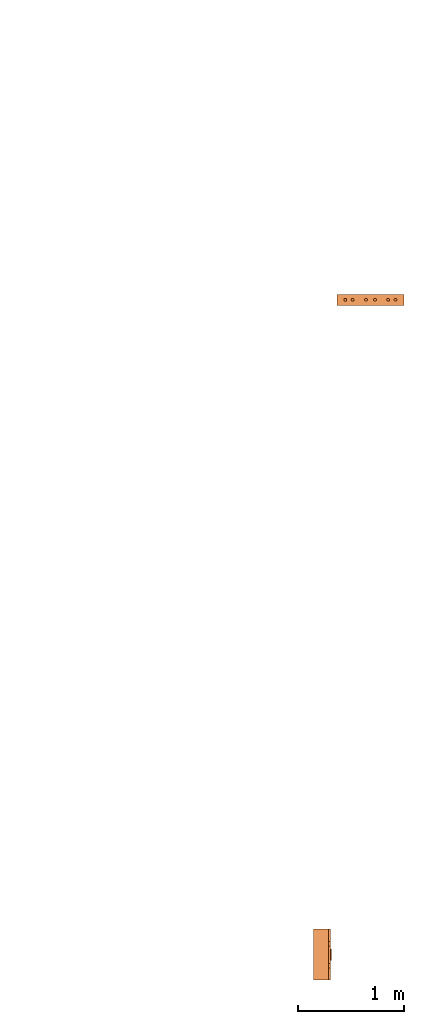
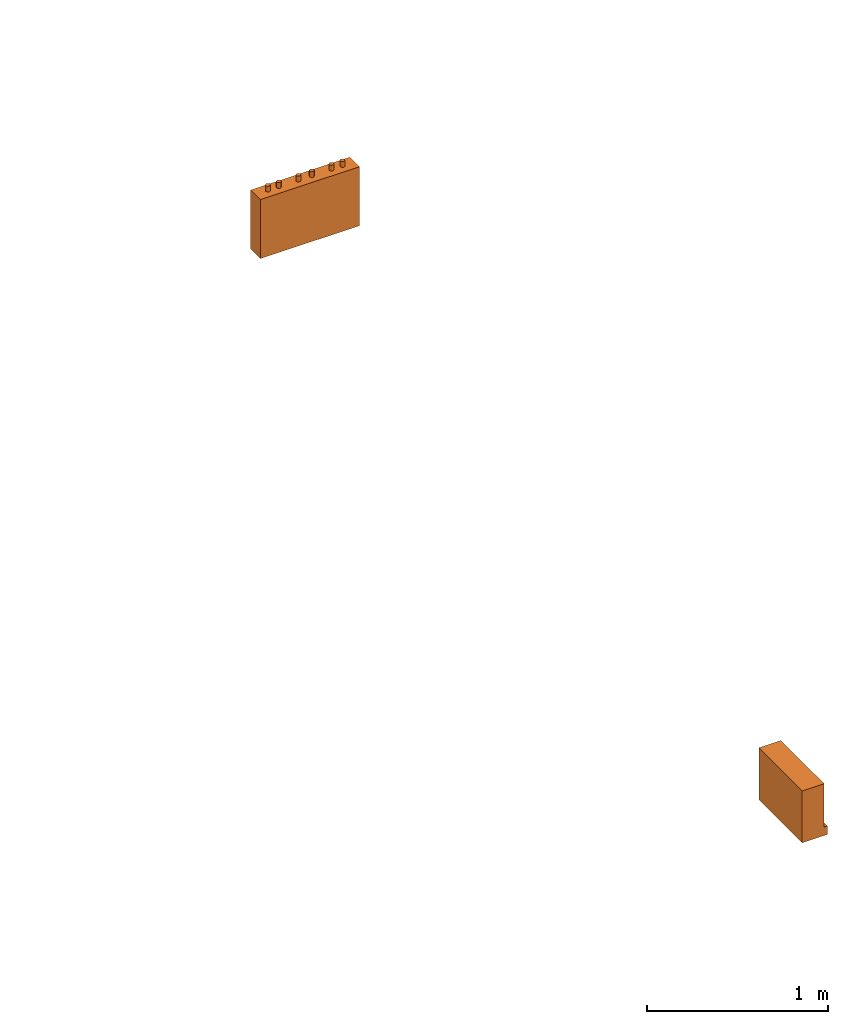
# One storey, part 2 of 3: 2 proxies.
"""IFC2X3 building model written with IfcOpenShell, lengths in millimetres."""

import ifcopenshell
import ifcopenshell.guid

model = None  # the IFC model being written
_history = None  # IfcOwnerHistory: only IFC2X3 demands one
_inside = {}  # id of a spatial element -> (the spatial element, [elements in it])
_under = {}  # id of a project, library or spatial element -> (it, [spatial elements below it])
_declared = {}  # id of a project -> (the project, [libraries it declares])
_typed = {}  # id of a type object -> (the type object, [elements of that type])
_made_of = {}  # id of a material, layer set ... -> (it, [elements and type objects made of it])


def new_model(schema):
    """Start an empty IFC model of exactly this schema.

    Asked for "IFC4X3", IfcOpenShell would pick the latest addendum, in which some entities
    have other attributes; the version numbers below select the first issue.
    IFC2X3 requires an IfcOwnerHistory on every rooted entity: one is made here for all.
    """
    global model, _history
    if schema == "IFC4X3":
        model = ifcopenshell.file(schema_version=(4, 3, 0, 0))
    else:
        model = ifcopenshell.file(schema=schema)
    _inside.clear()
    _under.clear()
    _declared.clear()
    _typed.clear()
    _made_of.clear()
    _history = None
    if model.schema == "IFC2X3":
        org = make("IfcOrganization", Name="unknown")
        user = make(
            "IfcPersonAndOrganization",
            ThePerson=make("IfcPerson", FamilyName="unknown"),
            TheOrganization=org,
        )
        app = make(
            "IfcApplication",
            ApplicationDeveloper=org,
            Version="unknown",
            ApplicationFullName="unknown",
            ApplicationIdentifier="unknown",
        )
        _history = make(
            "IfcOwnerHistory",
            OwningUser=user,
            OwningApplication=app,
            ChangeAction="ADDED",
            CreationDate=0,
        )
    return model


def make(cls, **values):
    """One entity of the class cls with the attributes given. An attribute that is None is left unset."""
    return model.create_entity(
        cls, **{name: value for name, value in values.items() if value is not None}
    )


def entity(cls, *values):
    """Any entity or typed value of the class cls, its attributes in the order of the schema. None: left unset."""
    e = model.create_entity(cls)
    for i, value in enumerate(values):
        if value is not None:
            e[i] = value
    return e


def rooted(cls, **values):
    """An entity with a GlobalId (a new one), such as an element, a storey or a relation."""
    return make(cls, GlobalId=ifcopenshell.guid.new(), OwnerHistory=_history, **values)


def si_unit(unit_type, name, prefix=None):
    """IfcSIUnit, for example si_unit("LENGTHUNIT", "METRE", prefix="MILLI")."""
    return make("IfcSIUnit", UnitType=unit_type, Prefix=prefix, Name=name)


def converted_unit(unit_type, name, factor, base, dimensions=None, offset=None):
    """IfcConversionBasedUnit, such as the inch: factor (a typed value) times the base unit."""
    return make(
        "IfcConversionBasedUnit"
        if offset is None
        else "IfcConversionBasedUnitWithOffset",
        ConversionOffset=offset,
        Dimensions=None
        if dimensions is None
        else entity("IfcDimensionalExponents", *dimensions),
        UnitType=unit_type,
        Name=name,
        ConversionFactor=make(
            "IfcMeasureWithUnit", ValueComponent=factor, UnitComponent=base
        ),
    )


def derived_unit(unit_type, elements):
    """IfcDerivedUnit: a product of units, each with its exponent."""
    return make(
        "IfcDerivedUnit",
        Elements=[
            make("IfcDerivedUnitElement", Unit=unit, Exponent=power)
            for unit, power in elements
        ],
        UnitType=unit_type,
    )


def assignment(units):
    """IfcUnitAssignment: the units of a project."""
    return None if units is None else make("IfcUnitAssignment", Units=units)


def point(xyz):
    """IfcCartesianPoint."""
    return None if xyz is None else make("IfcCartesianPoint", Coordinates=xyz)


def direction(xyz):
    """IfcDirection."""
    return None if xyz is None else make("IfcDirection", DirectionRatios=xyz)


def frame(location, z_axis=None, x_axis=None):
    """IfcAxis2Placement3D, a coordinate frame: its origin and axes. An axis left out is left unset."""
    return make(
        "IfcAxis2Placement3D",
        Location=point(location),
        Axis=direction(z_axis),
        RefDirection=direction(x_axis),
    )


def origin():
    """The frame at (0, 0, 0) with its axes left unset."""
    return frame((0.0, 0.0, 0.0))


def place(relative_to, where):
    """IfcLocalPlacement: puts the frame where relative to a parent placement (None: the world)."""
    return make(
        "IfcLocalPlacement", PlacementRelTo=relative_to, RelativePlacement=where
    )


def context(
    kind, dimensions, precision=None, world=None, true_north=None, identifier=None
):
    """IfcGeometricRepresentationContext, for example the 3D "Model" context."""
    return make(
        "IfcGeometricRepresentationContext",
        ContextIdentifier=identifier,
        ContextType=kind,
        CoordinateSpaceDimension=dimensions,
        Precision=precision,
        WorldCoordinateSystem=world,
        TrueNorth=true_north,
    )


def subcontext(parent, identifier, kind, view, scale=None):
    """IfcGeometricRepresentationSubContext, for example "Body" below "Model"."""
    return make(
        "IfcGeometricRepresentationSubContext",
        ContextIdentifier=identifier,
        ContextType=kind,
        ParentContext=parent,
        TargetScale=scale,
        TargetView=view,
    )


def project(units=None, contexts=None):
    """IfcProject with its units and contexts."""
    return rooted(
        "IfcProject",
        Name="project",
        RepresentationContexts=contexts,
        UnitsInContext=assignment(units),
    )


def spatial(cls, under=None, at=None, **own):
    """A site, building, storey or space (cls), placed at a placement, below another one or the project."""
    s = rooted(cls, ObjectPlacement=at, **own)
    if under is not None:
        _under.setdefault(under.id(), (under, []))[1].append(s)
    return s


def faces_of(points, faces, orient=None, outer=None):
    """IfcFace entities. A face is a list of loops; a loop is a list of indices into points, from 0.

    orient and outer hold one flag for each loop. By default every Orientation is true, the
    first loop of a face is its IfcFaceOuterBound and the others are IfcFaceBound.
    """
    made = []
    for i, loops in enumerate(faces):
        bounds = []
        for j, loop in enumerate(loops):
            is_outer = j == 0 if outer is None else outer[i][j]
            bounds.append(
                make(
                    "IfcFaceOuterBound" if is_outer else "IfcFaceBound",
                    Bound=make("IfcPolyLoop", Polygon=[points[k] for k in loop]),
                    Orientation=True if orient is None else orient[i][j],
                )
            )
        made.append(make("IfcFace", Bounds=bounds))
    return made


def faceted_brep(points, faces, orient=None, outer=None, voids=None):
    """IfcFacetedBrep: a solid bounded by flat faces; with voids (closed shells), ...WithVoids."""
    shared = [point(p) for p in points]
    hull = make("IfcClosedShell", CfsFaces=faces_of(shared, faces, orient, outer))
    if voids is None:
        return make("IfcFacetedBrep", Outer=hull)
    return make(
        "IfcFacetedBrepWithVoids",
        Outer=hull,
        Voids=[
            make(cls, CfsFaces=faces_of(shared, fs, o, b)) for cls, fs, o, b in voids
        ],
    )


def shape(context_of_items, identifier, shape_type, items):
    """IfcShapeRepresentation: the items that make up one representation, for example the "Body"."""
    return make(
        "IfcShapeRepresentation",
        ContextOfItems=context_of_items,
        RepresentationIdentifier=identifier,
        RepresentationType=shape_type,
        Items=items,
    )


def source(mapping_origin, context_of_items, identifier, shape_type, items):
    """IfcRepresentationMap: a shape defined once, which mapped items show again and again."""
    return make(
        "IfcRepresentationMap",
        MappingOrigin=mapping_origin,
        MappedRepresentation=shape(context_of_items, identifier, shape_type, items),
    )


def transform(
    local_origin,
    x_axis=None,
    y_axis=None,
    z_axis=None,
    scale=None,
    scale2=None,
    scale3=None,
    uniform=True,
):
    """IfcCartesianTransformationOperator3D, or its non-uniform kind. x_axis, y_axis, z_axis: its Axis1, 2, 3."""
    if uniform:
        return make(
            "IfcCartesianTransformationOperator3D",
            Axis1=direction(x_axis),
            Axis2=direction(y_axis),
            LocalOrigin=point(local_origin),
            Scale=scale,
            Axis3=direction(z_axis),
        )
    return make(
        "IfcCartesianTransformationOperator3DnonUniform",
        Axis1=direction(x_axis),
        Axis2=direction(y_axis),
        LocalOrigin=point(local_origin),
        Scale=scale,
        Axis3=direction(z_axis),
        Scale2=scale2,
        Scale3=scale3,
    )


def mapped(mapping_source, mapping_target):
    """IfcMappedItem: shows the shape of a source again, moved by a transform."""
    return make(
        "IfcMappedItem", MappingSource=mapping_source, MappingTarget=mapping_target
    )


def material(Name=None, Category=None):
    """IfcMaterial."""
    return make("IfcMaterial", Name=Name, Category=Category)


def material_list(materials):
    """IfcMaterialList."""
    return make("IfcMaterialList", Materials=materials)


def made_of(thing, what):
    """Note that an element or type object is made of a material, layer set ...; save() writes the relation."""
    if what is not None:
        _made_of.setdefault(what.id(), (what, []))[1].append(thing)
    return thing


def type_object(cls, material=None, **own):
    """A type object (cls), such as IfcWallType, which elements share."""
    return made_of(rooted(cls, **own), material)


def type_shapes(of_type, sources):
    """Give a type object the sources (RepresentationMaps) that its elements show as mapped items."""
    of_type.RepresentationMaps = sources


def element(
    cls,
    number,
    at=None,
    inside=None,
    cuts=None,
    type_object=None,
    material=None,
    context=None,
    identifier="Body",
    shape_type=None,
    held_by="IfcProductDefinitionShape",
    body=None,
    shapes=None,
    **own,
):
    """One element of the class cls, such as IfcWall. Its Tag is "e" and its number.

    at: its placement. inside: the storey or other place that contains it. cuts: it is an
    opening in that element (IfcRelVoidsElement). A single representation is given by context,
    identifier, shape_type and body (its items); several are given by shapes. held_by: the class
    of the entity that holds the representations. save() writes the other relations.
    """
    e = rooted(cls, Tag="e%d" % number, ObjectPlacement=at, **own)
    if body is not None:
        shapes = [shape(context, identifier, shape_type, body)]
    if shapes is not None:
        e.Representation = make(held_by, Representations=shapes)
    if inside is not None:
        _inside.setdefault(inside.id(), (inside, []))[1].append(e)
    if cuts is not None:
        rooted(
            "IfcRelVoidsElement", RelatingBuildingElement=cuts, RelatedOpeningElement=e
        )
    if type_object is not None:
        _typed.setdefault(type_object.id(), (type_object, []))[1].append(e)
    return made_of(e, material)


def aggregate(whole, parts):
    """IfcRelAggregates: a whole, such as a stair, and the parts it consists of."""
    return rooted("IfcRelAggregates", RelatingObject=whole, RelatedObjects=parts)


def save(model, path):
    """Write the relations noted so far, then the file.

    IfcRelAggregates (storeys below a building ...), IfcRelContainedInSpatialStructure (elements
    in a storey), IfcRelDefinesByType, IfcRelAssociatesMaterial and IfcRelDeclares: one each for
    every whole, place, type object, material and project.
    """
    for whole, parts in _under.values():
        aggregate(whole, parts)
    for where, things in _inside.values():
        rooted(
            "IfcRelContainedInSpatialStructure",
            RelatedElements=things,
            RelatingStructure=where,
        )
    for kind, things in _typed.values():
        rooted("IfcRelDefinesByType", RelatedObjects=things, RelatingType=kind)
    for what, things in _made_of.values():
        rooted("IfcRelAssociatesMaterial", RelatedObjects=things, RelatingMaterial=what)
    for by, libraries in _declared.values():
        rooted("IfcRelDeclares", RelatingContext=by, RelatedDefinitions=libraries)
    model.write(path)


model = new_model("IFC2X3")

# Units and contexts
model_context = context("Model", 3, precision=0.01, world=origin(), true_north=direction((6.12303176911189e-17, 1.0)))
body_context = subcontext(model_context, "Body", "Model", "MODEL_VIEW")
ifc_project = project(units=[si_unit("LENGTHUNIT", "METRE", prefix="MILLI"), si_unit("AREAUNIT", "SQUARE_METRE"), si_unit("VOLUMEUNIT", "CUBIC_METRE"), converted_unit("PLANEANGLEUNIT", "DEGREE", entity("IfcRatioMeasure", 0.0174532925199433), si_unit("PLANEANGLEUNIT", "RADIAN"), dimensions=[0, 0, 0, 0, 0, 0, 0]), si_unit("MASSUNIT", "GRAM", prefix="KILO"), derived_unit("MASSDENSITYUNIT", [(si_unit("MASSUNIT", "GRAM", prefix="KILO"), 1), (si_unit("LENGTHUNIT", "METRE"), -3)]), derived_unit("MOMENTOFINERTIAUNIT", [(si_unit("LENGTHUNIT", "METRE"), 4)]), si_unit("TIMEUNIT", "SECOND"), si_unit("FREQUENCYUNIT", "HERTZ"), si_unit("THERMODYNAMICTEMPERATUREUNIT", "DEGREE_CELSIUS"), derived_unit("THERMALTRANSMITTANCEUNIT", [(si_unit("MASSUNIT", "GRAM", prefix="KILO"), 1), (si_unit("THERMODYNAMICTEMPERATUREUNIT", "KELVIN"), -1), (si_unit("TIMEUNIT", "SECOND"), -3)]), derived_unit("VOLUMETRICFLOWRATEUNIT", [(si_unit("LENGTHUNIT", "METRE"), 3), (si_unit("TIMEUNIT", "SECOND"), -1)]), derived_unit("MASSFLOWRATEUNIT", [(si_unit("MASSUNIT", "GRAM", prefix="KILO"), 1), (si_unit("TIMEUNIT", "SECOND"), -1)]), derived_unit("ROTATIONALFREQUENCYUNIT", [(si_unit("TIMEUNIT", "SECOND"), -1)]), si_unit("ELECTRICCURRENTUNIT", "AMPERE"), si_unit("ELECTRICVOLTAGEUNIT", "VOLT"), si_unit("POWERUNIT", "WATT"), si_unit("FORCEUNIT", "NEWTON", prefix="KILO"), si_unit("ILLUMINANCEUNIT", "LUX"), si_unit("LUMINOUSFLUXUNIT", "LUMEN"), si_unit("LUMINOUSINTENSITYUNIT", "CANDELA"), derived_unit("USERDEFINED", [(si_unit("MASSUNIT", "GRAM", prefix="KILO"), -1), (si_unit("LENGTHUNIT", "METRE"), -2), (si_unit("TIMEUNIT", "SECOND"), 3), (si_unit("LUMINOUSFLUXUNIT", "LUMEN"), 1)]), derived_unit("LINEARVELOCITYUNIT", [(si_unit("LENGTHUNIT", "METRE"), 1), (si_unit("TIMEUNIT", "SECOND"), -1)]), si_unit("PRESSUREUNIT", "PASCAL"), derived_unit("USERDEFINED", [(si_unit("LENGTHUNIT", "METRE"), -2), (si_unit("MASSUNIT", "GRAM", prefix="KILO"), 1), (si_unit("TIMEUNIT", "SECOND"), -2)]), derived_unit("LINEARFORCEUNIT", [(si_unit("MASSUNIT", "GRAM", prefix="KILO"), 1), (si_unit("LENGTHUNIT", "METRE"), 1), (si_unit("TIMEUNIT", "SECOND"), -2), (si_unit("LENGTHUNIT", "METRE"), -1)]), derived_unit("PLANARFORCEUNIT", [(si_unit("MASSUNIT", "GRAM", prefix="KILO"), 1), (si_unit("LENGTHUNIT", "METRE"), 1), (si_unit("TIMEUNIT", "SECOND"), -2), (si_unit("LENGTHUNIT", "METRE"), -2)])], contexts=[model_context])

# Site, building, storey
site_placement = place(None, frame((0.0, 2493.83037508239, 0.0)))
site = spatial("IfcSite", under=ifc_project, at=site_placement, CompositionType="ELEMENT")
building_placement = place(site_placement, origin())
building = spatial("IfcBuilding", under=site, at=building_placement, CompositionType="ELEMENT")
storey_placement = place(building_placement, frame((0.0, 0.0, 12000.0)))
storey = spatial("IfcBuildingStorey", under=building, at=storey_placement, Name="04", CompositionType="ELEMENT", Elevation=12000.0)

# Proxies
ifc_material_1 = material()
ifc_material_2 = material()
ifc_material_list_1 = material_list([ifc_material_1, ifc_material_2])
building_element_proxy_type_1 = type_object("IfcBuildingElementProxyType", PredefinedType="NOTDEFINED", material=ifc_material_1)
shared_shape_1 = source(origin(), body_context, "Body", "Brep", [
    faceted_brep([(168.201612490282, 212.500000000001, 135.54049916809), (168.201612490282, 201.109127034741, 126.799974925206), (168.201612490282, 192.368602791857, 115.409101959946), (168.201612490282, 186.874079554102, 102.144149440585), (168.201612490282, 185.0, 87.9091019599461), (168.201612490282, 186.874079554102, 73.6740544793074), (168.201612490282, 192.368602791856, 60.4091019599461), (168.201612490282, 201.10912703474, 49.0182289946861), (168.201612490282, 212.500000000001, 40.2777047518019), (168.201612490282, 225.764952519362, 34.7831815140474), (168.201612490282, 240.0, 32.9091019599461), (168.201612490282, 254.235047480639, 34.7831815140472), (168.201612490282, 267.5, 40.2777047518019), (168.201612490282, 278.890872965261, 49.0182289946858), (168.201612490282, 287.631397208145, 60.4091019599458), (168.201612490282, 293.125920445899, 73.6740544793071), (168.201612490282, 295.0, 87.9091019599458), (168.201612490282, 293.125920445899, 102.144149440584), (168.201612490282, 287.631397208145, 115.409101959946), (168.201612490282, 278.890872965261, 126.799974925206), (168.201612490282, 267.500000000001, 135.54049916809), (168.201612490282, 254.235047480639, 141.035022405845), (168.201612490282, 240.0, 142.909101959946), (168.201612490282, 225.764952519362, 141.035022405845), (160.0, 225.764952519362, 34.7831815140474), (160.0, 212.500000000001, 40.2777047518019), (160.0, 201.10912703474, 49.0182289946861), (160.0, 192.368602791856, 60.4091019599461), (160.0, 186.874079554102, 73.6740544793074), (160.0, 185.0, 87.9091019599463), (160.0, 186.874079554102, 102.144149440585), (160.0, 192.368602791857, 115.409101959946), (160.0, 201.109127034741, 126.799974925206), (160.0, 212.500000000001, 135.54049916809), (160.0, 225.764952519362, 141.035022405845), (160.0, 240.0, 142.909101959946), (160.0, 254.235047480639, 141.035022405845), (160.0, 267.500000000001, 135.54049916809), (160.0, 278.890872965261, 126.799974925206), (160.0, 287.631397208145, 115.409101959946), (160.0, 293.125920445899, 102.144149440584), (160.0, 295.0, 87.9091019599458), (160.0, 293.125920445899, 73.6740544793071), (160.0, 287.631397208145, 60.4091019599458), (160.0, 278.890872965261, 49.0182289946858), (160.0, 267.5, 40.2777047518019), (160.0, 254.235047480639, 34.7831815140472), (160.0, 240.0, 32.9091019599461)], [[[0, 1, 2, 3, 4, 5, 6, 7, 8, 9, 10, 11, 12, 13, 14, 15, 16, 17, 18, 19, 20, 21, 22, 23]], [[24, 25, 26, 27, 28, 29, 30, 31, 32, 33, 34, 35, 36, 37, 38, 39, 40, 41, 42, 43, 44, 45, 46, 47]], [[40, 17, 16, 41]], [[39, 18, 17, 40]], [[20, 19, 38, 37]], [[39, 38, 19, 18]], [[21, 20, 37, 36]], [[22, 21, 36, 35]], [[34, 23, 22, 35]], [[33, 0, 23, 34]], [[2, 1, 32, 31]], [[33, 32, 1, 0]], [[3, 2, 31, 30]], [[4, 3, 30, 29]], [[28, 5, 4, 29]], [[27, 6, 5, 28]], [[8, 7, 26, 25]], [[27, 26, 7, 6]], [[9, 8, 25, 24]], [[10, 9, 24, 47]], [[46, 11, 10, 47]], [[45, 12, 11, 46]], [[14, 13, 44, 43]], [[45, 44, 13, 12]], [[15, 14, 43, 42]], [[16, 15, 42, 41]]]),
    faceted_brep([(160.0, 0.0, 0.0), (160.0, 480.0, 0.0), (160.0, 480.0, 58.2870579365997), (160.0, 365.0, 58.2870579366005), (160.0, 322.247482084292, 175.748635534839), (160.0, 157.75251791571, 175.748635534839), (160.0, 115.0, 58.2870579366), (160.0, 0.0, 58.2870579365997), (0.0, 480.0, 0.0), (0.0, 0.0, 0.0), (0.0, 0.0, 350.0), (0.0, 480.0, 350.0), (140.211167148102, 480.0, 350.0), (140.211167148102, 480.0, 58.2870579365997), (140.211167148102, 0.0, 350.0), (140.211167148102, 0.0, 58.2870579365997), (140.211167148102, 365.0, 58.2870579366), (140.211167148102, 115.0, 58.2870579366), (140.211167148102, 157.75251791571, 175.748635534839), (140.211167148102, 322.247482084292, 175.748635534839)], [[[0, 1, 2, 3, 4, 5, 6, 7]], [[8, 9, 10, 11]], [[8, 11, 12, 13, 2, 1]], [[11, 10, 14, 12]], [[10, 9, 0, 7, 15, 14]], [[1, 0, 9, 8]], [[16, 13, 12, 14, 15, 17, 18, 19]], [[13, 16, 3, 2]], [[17, 15, 7, 6]], [[18, 17, 6, 5]], [[19, 18, 5, 4]], [[16, 19, 4, 3]]]),
])
type_shapes(building_element_proxy_type_1, [shared_shape_1])
proxy_1_placement = place(storey_placement, frame((62632.608534949, -553.831148726475, 1500.0)))
element("IfcBuildingElementProxy", 1, at=proxy_1_placement, inside=storey, type_object=building_element_proxy_type_1, material=ifc_material_list_1, context=body_context, shape_type="MappedRepresentation", body=[
    mapped(shared_shape_1, transform((0.0, 0.0, 0.0), scale=1.0)),
])
ifc_material_3 = material()
ifc_material_list_2 = material_list([ifc_material_3, ifc_material_2])
building_element_proxy_type_2 = type_object("IfcBuildingElementProxyType", PredefinedType="NOTDEFINED", material=ifc_material_3)
shared_shape_2 = source(origin(), body_context, "Body", "Brep", [
    faceted_brep([(61.7366777047886, 89.258069163288, 398.0), (63.9615384211591, 86.3585742266764, 398.0), (65.3601443362239, 82.9820408581116, 398.0), (65.837182768177, 79.3585742266763, 398.0), (65.3601443362239, 75.735107595241, 398.0), (63.9615384211591, 72.3585742266763, 398.0), (61.7366777047886, 69.4590792900646, 398.0), (58.8371827681769, 67.2342185736942, 398.0), (55.4606493996122, 65.8356126586294, 398.0), (51.8371827681769, 65.3585742266764, 398.0), (48.2137161367416, 65.8356126586295, 398.0), (44.8371827681769, 67.2342185736943, 398.0), (41.9376878315653, 69.4590792900647, 398.0), (39.7128271151948, 72.3585742266764, 398.0), (38.31422120013, 75.7351075952411, 398.0), (37.837182768177, 79.3585742266764, 398.0), (38.31422120013, 82.9820408581117, 398.0), (39.7128271151949, 86.3585742266764, 398.0), (41.9376878315653, 89.258069163288, 398.0), (44.837182768177, 91.4829298796585, 398.0), (48.2137161367417, 92.8815357947233, 398.0), (51.837182768177, 93.3585742266764, 398.0), (55.4606493996123, 92.8815357947233, 398.0), (58.837182768177, 91.4829298796585, 398.0), (58.8371827681769, 67.2342185736942, 436.716690815491), (61.7366777047886, 69.4590792900646, 436.716690815491), (63.9615384211591, 72.3585742266763, 436.716690815491), (65.3601443362239, 75.735107595241, 436.716690815491), (65.837182768177, 79.3585742266764, 436.716690815491), (65.3601443362239, 82.9820408581116, 436.716690815491), (63.9615384211591, 86.3585742266764, 436.716690815491), (61.7366777047886, 89.258069163288, 436.716690815491), (58.837182768177, 91.4829298796585, 436.716690815491), (55.4606493996123, 92.8815357947233, 436.716690815491), (51.837182768177, 93.3585742266764, 436.716690815491), (48.2137161367417, 92.8815357947233, 436.716690815491), (44.837182768177, 91.4829298796585, 436.716690815491), (41.9376878315653, 89.258069163288, 436.716690815491), (39.7128271151949, 86.3585742266764, 436.716690815491), (38.31422120013, 82.9820408581117, 436.716690815491), (37.837182768177, 79.3585742266764, 436.716690815491), (38.31422120013, 75.7351075952411, 436.716690815491), (39.7128271151948, 72.3585742266764, 436.716690815491), (41.9376878315653, 69.4590792900647, 436.716690815491), (44.8371827681769, 67.2342185736943, 436.716690815491), (48.2137161367416, 65.8356126586295, 436.716690815491), (51.8371827681769, 65.3585742266764, 436.716690815491), (55.4606493996122, 65.8356126586294, 436.716690815491)], [[[0, 1, 2, 3, 4, 5, 6, 7, 8, 9, 10, 11, 12, 13, 14, 15, 16, 17, 18, 19, 20, 21, 22, 23]], [[24, 25, 26, 27, 28, 29, 30, 31, 32, 33, 34, 35, 36, 37, 38, 39, 40, 41, 42, 43, 44, 45, 46, 47]], [[40, 15, 14, 41]], [[13, 42, 41, 14]], [[43, 12, 11, 44]], [[13, 12, 43, 42]], [[44, 11, 10, 45]], [[9, 46, 45, 10]], [[47, 8, 7, 24]], [[6, 25, 24, 7]], [[26, 5, 4, 27]], [[6, 5, 26, 25]], [[27, 4, 3, 28]], [[47, 46, 9, 8]], [[1, 30, 29, 2]], [[0, 31, 30, 1]], [[22, 33, 32, 23]], [[23, 32, 31, 0]], [[21, 34, 33, 22]], [[28, 3, 2, 29]], [[35, 20, 19, 36]], [[18, 37, 36, 19]], [[38, 17, 16, 39]], [[18, 17, 38, 37]], [[39, 16, 15, 40]], [[35, 34, 21, 20]]]),
    faceted_brep([(58.837182768177, 542.517070120343, 436.716690815491), (61.7366777047886, 544.741930836713, 436.716690815491), (63.9615384211591, 547.641425773325, 436.716690815491), (65.360144336224, 551.017959141889, 436.716690815491), (65.837182768177, 554.641425773325, 436.716690815491), (65.360144336224, 558.26489240476, 436.716690815491), (63.9615384211592, 561.641425773325, 436.716690815491), (61.7366777047887, 564.540920709937, 436.716690815491), (58.8371827681771, 566.765781426307, 436.716690815491), (55.4606493996123, 568.164387341372, 436.716690815491), (51.8371827681771, 568.641425773325, 436.716690815491), (48.2137161367418, 568.164387341372, 436.716690815491), (44.8371827681771, 566.765781426307, 436.716690815491), (41.9376878315654, 564.540920709937, 436.716690815491), (39.7128271151949, 561.641425773325, 436.716690815491), (38.3142212001301, 558.26489240476, 436.716690815491), (37.837182768177, 554.641425773325, 436.716690815491), (38.3142212001301, 551.01795914189, 436.716690815491), (39.7128271151949, 547.641425773325, 436.716690815491), (41.9376878315653, 544.741930836713, 436.716690815491), (44.837182768177, 542.517070120343, 436.716690815491), (48.2137161367417, 541.118464205278, 436.716690815491), (51.837182768177, 540.641425773325, 436.716690815491), (55.4606493996123, 541.118464205278, 436.716690815491), (51.8371827681771, 568.641425773325, 398.0), (55.4606493996123, 568.164387341372, 398.0), (58.8371827681771, 566.765781426307, 398.0), (61.7366777047887, 564.540920709937, 398.0), (63.9615384211592, 561.641425773325, 398.0), (65.360144336224, 558.26489240476, 398.0), (65.837182768177, 554.641425773325, 398.0), (65.360144336224, 551.017959141889, 398.0), (63.9615384211591, 547.641425773325, 398.0), (61.7366777047886, 544.741930836713, 398.0), (58.837182768177, 542.517070120343, 398.0), (55.4606493996123, 541.118464205278, 398.0), (51.837182768177, 540.641425773325, 398.0), (48.2137161367417, 541.118464205278, 398.0), (44.837182768177, 542.517070120343, 398.0), (41.9376878315653, 544.741930836713, 398.0), (39.7128271151949, 547.641425773325, 398.0), (38.3142212001301, 551.01795914189, 398.0), (37.837182768177, 554.641425773325, 398.0), (38.3142212001301, 558.26489240476, 398.0), (39.7128271151949, 561.641425773325, 398.0), (41.9376878315654, 564.540920709937, 398.0), (44.8371827681771, 566.765781426307, 398.0), (48.2137161367418, 568.164387341372, 398.0)], [[[0, 1, 2, 3, 4, 5, 6, 7, 8, 9, 10, 11, 12, 13, 14, 15, 16, 17, 18, 19, 20, 21, 22, 23]], [[24, 25, 26, 27, 28, 29, 30, 31, 32, 33, 34, 35, 36, 37, 38, 39, 40, 41, 42, 43, 44, 45, 46, 47]], [[17, 41, 40, 18]], [[39, 19, 18, 40]], [[20, 38, 37, 21]], [[39, 38, 20, 19]], [[21, 37, 36, 22]], [[41, 17, 16, 42]], [[23, 35, 34, 0]], [[33, 1, 0, 34]], [[2, 32, 31, 3]], [[33, 32, 2, 1]], [[3, 31, 30, 4]], [[35, 23, 22, 36]], [[29, 5, 4, 30]], [[28, 6, 5, 29]], [[9, 25, 24, 10]], [[27, 7, 6, 28]], [[26, 8, 7, 27]], [[26, 25, 9, 8]], [[11, 47, 46, 12]], [[45, 13, 12, 46]], [[14, 44, 43, 15]], [[45, 44, 14, 13]], [[15, 43, 42, 16]], [[47, 11, 10, 24]]]),
    faceted_brep([(58.8371827681769, 472.517070120343, 436.716690815491), (61.7366777047886, 474.741930836713, 436.716690815491), (63.961538421159, 477.641425773325, 436.716690815491), (65.3601443362239, 481.017959141889, 436.716690815491), (65.8371827681769, 484.641425773325, 436.716690815491), (65.3601443362239, 488.26489240476, 436.716690815491), (63.9615384211591, 491.641425773325, 436.716690815491), (61.7366777047886, 494.540920709936, 436.716690815491), (58.837182768177, 496.765781426307, 436.716690815491), (55.4606493996123, 498.164387341372, 436.716690815491), (51.837182768177, 498.641425773325, 436.716690815491), (48.2137161367417, 498.164387341372, 436.716690815491), (44.837182768177, 496.765781426307, 436.716690815491), (41.9376878315653, 494.540920709937, 436.716690815491), (39.7128271151948, 491.641425773325, 436.716690815491), (38.31422120013, 488.26489240476, 436.716690815491), (37.837182768177, 484.641425773325, 436.716690815491), (38.31422120013, 481.01795914189, 436.716690815491), (39.7128271151948, 477.641425773325, 436.716690815491), (41.9376878315653, 474.741930836713, 436.716690815491), (44.8371827681769, 472.517070120343, 436.716690815491), (48.2137161367416, 471.118464205278, 436.716690815491), (51.8371827681769, 470.641425773325, 436.716690815491), (55.4606493996122, 471.118464205278, 436.716690815491), (51.837182768177, 498.641425773325, 398.0), (55.4606493996123, 498.164387341372, 398.0), (58.837182768177, 496.765781426307, 398.0), (61.7366777047886, 494.540920709936, 398.0), (63.9615384211591, 491.641425773325, 398.0), (65.3601443362239, 488.26489240476, 398.0), (65.8371827681769, 484.641425773325, 398.0), (65.3601443362239, 481.017959141889, 398.0), (63.961538421159, 477.641425773325, 398.0), (61.7366777047886, 474.741930836713, 398.0), (58.8371827681769, 472.517070120343, 398.0), (55.4606493996122, 471.118464205278, 398.0), (51.8371827681769, 470.641425773325, 398.0), (48.2137161367416, 471.118464205278, 398.0), (44.8371827681769, 472.517070120343, 398.0), (41.9376878315653, 474.741930836713, 398.0), (39.7128271151948, 477.641425773325, 398.0), (38.31422120013, 481.01795914189, 398.0), (37.837182768177, 484.641425773325, 398.0), (38.31422120013, 488.26489240476, 398.0), (39.7128271151948, 491.641425773325, 398.0), (41.9376878315653, 494.540920709937, 398.0), (44.837182768177, 496.765781426307, 398.0), (48.2137161367417, 498.164387341372, 398.0)], [[[0, 1, 2, 3, 4, 5, 6, 7, 8, 9, 10, 11, 12, 13, 14, 15, 16, 17, 18, 19, 20, 21, 22, 23]], [[24, 25, 26, 27, 28, 29, 30, 31, 32, 33, 34, 35, 36, 37, 38, 39, 40, 41, 42, 43, 44, 45, 46, 47]], [[16, 42, 41, 17]], [[40, 18, 17, 41]], [[19, 39, 38, 20]], [[40, 39, 19, 18]], [[20, 38, 37, 21]], [[36, 22, 21, 37]], [[23, 35, 34, 0]], [[33, 1, 0, 34]], [[2, 32, 31, 3]], [[33, 32, 2, 1]], [[3, 31, 30, 4]], [[23, 22, 36, 35]], [[28, 6, 5, 29]], [[27, 7, 6, 28]], [[25, 9, 8, 26]], [[26, 8, 7, 27]], [[24, 10, 9, 25]], [[4, 30, 29, 5]], [[11, 47, 46, 12]], [[45, 13, 12, 46]], [[14, 44, 43, 15]], [[45, 44, 14, 13]], [[15, 43, 42, 16]], [[11, 10, 24, 47]]]),
    faceted_brep([(58.8371827681766, 347.517070120343, 436.716690815491), (61.7366777047883, 349.741930836713, 436.716690815491), (63.9615384211588, 352.641425773325, 436.716690815491), (65.3601443362236, 356.017959141889, 436.716690815491), (65.8371827681767, 359.641425773325, 436.716690815491), (65.3601443362237, 363.26489240476, 436.716690815491), (63.9615384211589, 366.641425773325, 436.716690815491), (61.7366777047884, 369.540920709937, 436.716690815491), (58.8371827681767, 371.765781426307, 436.716690815491), (55.460649399612, 373.164387341372, 436.716690815491), (51.8371827681767, 373.641425773325, 436.716690815491), (48.2137161367414, 373.164387341372, 436.716690815491), (44.8371827681767, 371.765781426307, 436.716690815491), (41.9376878315651, 369.540920709937, 436.716690815491), (39.7128271151946, 366.641425773325, 436.716690815491), (38.3142212001298, 363.26489240476, 436.716690815491), (37.8371827681767, 359.641425773325, 436.716690815491), (38.3142212001298, 356.01795914189, 436.716690815491), (39.7128271151945, 352.641425773325, 436.716690815491), (41.937687831565, 349.741930836713, 436.716690815491), (44.8371827681767, 347.517070120343, 436.716690815491), (48.2137161367414, 346.118464205278, 436.716690815491), (51.8371827681766, 345.641425773325, 436.716690815491), (55.4606493996119, 346.118464205278, 436.716690815491), (51.8371827681767, 373.641425773325, 398.0), (55.460649399612, 373.164387341372, 398.0), (58.8371827681767, 371.765781426307, 398.0), (61.7366777047884, 369.540920709937, 398.0), (63.9615384211589, 366.641425773325, 398.0), (65.3601443362237, 363.26489240476, 398.0), (65.8371827681767, 359.641425773325, 398.0), (65.3601443362236, 356.017959141889, 398.0), (63.9615384211588, 352.641425773325, 398.0), (61.7366777047883, 349.741930836713, 398.0), (58.8371827681766, 347.517070120343, 398.0), (55.4606493996119, 346.118464205278, 398.0), (51.8371827681766, 345.641425773325, 398.0), (48.2137161367414, 346.118464205278, 398.0), (44.8371827681767, 347.517070120343, 398.0), (41.937687831565, 349.741930836713, 398.0), (39.7128271151945, 352.641425773325, 398.0), (38.3142212001298, 356.01795914189, 398.0), (37.8371827681767, 359.641425773325, 398.0), (38.3142212001298, 363.26489240476, 398.0), (39.7128271151946, 366.641425773325, 398.0), (41.9376878315651, 369.540920709937, 398.0), (44.8371827681767, 371.765781426307, 398.0), (48.2137161367414, 373.164387341372, 398.0)], [[[0, 1, 2, 3, 4, 5, 6, 7, 8, 9, 10, 11, 12, 13, 14, 15, 16, 17, 18, 19, 20, 21, 22, 23]], [[24, 25, 26, 27, 28, 29, 30, 31, 32, 33, 34, 35, 36, 37, 38, 39, 40, 41, 42, 43, 44, 45, 46, 47]], [[16, 42, 41, 17]], [[40, 18, 17, 41]], [[19, 39, 38, 20]], [[40, 39, 19, 18]], [[20, 38, 37, 21]], [[36, 22, 21, 37]], [[23, 35, 34, 0]], [[33, 1, 0, 34]], [[2, 32, 31, 3]], [[33, 32, 2, 1]], [[3, 31, 30, 4]], [[23, 22, 36, 35]], [[28, 6, 5, 29]], [[27, 7, 6, 28]], [[25, 9, 8, 26]], [[26, 8, 7, 27]], [[24, 10, 9, 25]], [[4, 30, 29, 5]], [[11, 47, 46, 12]], [[45, 13, 12, 46]], [[14, 44, 43, 15]], [[45, 44, 14, 13]], [[15, 43, 42, 16]], [[11, 10, 24, 47]]]),
    faceted_brep([(58.8371827681766, 262.234218573694, 436.716690815491), (61.7366777047883, 264.459079290065, 436.716690815491), (63.9615384211588, 267.358574226676, 436.716690815491), (65.3601443362236, 270.735107595241, 436.716690815491), (65.8371827681767, 274.358574226676, 436.716690815491), (65.3601443362237, 277.982040858112, 436.716690815491), (63.9615384211588, 281.358574226676, 436.716690815491), (61.7366777047884, 284.258069163288, 436.716690815491), (58.8371827681767, 286.482929879658, 436.716690815491), (55.460649399612, 287.881535794723, 436.716690815491), (51.8371827681767, 288.358574226676, 436.716690815491), (48.2137161367414, 287.881535794723, 436.716690815491), (44.8371827681767, 286.482929879659, 436.716690815491), (41.9376878315651, 284.258069163288, 436.716690815491), (39.7128271151946, 281.358574226676, 436.716690815491), (38.3142212001298, 277.982040858112, 436.716690815491), (37.8371827681767, 274.358574226676, 436.716690815491), (38.3142212001297, 270.735107595241, 436.716690815491), (39.7128271151945, 267.358574226676, 436.716690815491), (41.937687831565, 264.459079290065, 436.716690815491), (44.8371827681767, 262.234218573694, 436.716690815491), (48.2137161367414, 260.835612658629, 436.716690815491), (51.8371827681766, 260.358574226676, 436.716690815491), (55.4606493996119, 260.835612658629, 436.716690815491), (51.8371827681767, 288.358574226676, 398.0), (55.460649399612, 287.881535794723, 398.0), (58.8371827681767, 286.482929879658, 398.0), (61.7366777047884, 284.258069163288, 398.0), (63.9615384211588, 281.358574226676, 398.0), (65.3601443362237, 277.982040858112, 398.0), (65.8371827681767, 274.358574226676, 398.0), (65.3601443362236, 270.735107595241, 398.0), (63.9615384211588, 267.358574226676, 398.0), (61.7366777047883, 264.459079290065, 398.0), (58.8371827681766, 262.234218573694, 398.0), (55.4606493996119, 260.835612658629, 398.0), (51.8371827681766, 260.358574226676, 398.0), (48.2137161367414, 260.835612658629, 398.0), (44.8371827681767, 262.234218573694, 398.0), (41.937687831565, 264.459079290065, 398.0), (39.7128271151945, 267.358574226676, 398.0), (38.3142212001297, 270.735107595241, 398.0), (37.8371827681767, 274.358574226676, 398.0), (38.3142212001298, 277.982040858112, 398.0), (39.7128271151946, 281.358574226676, 398.0), (41.9376878315651, 284.258069163288, 398.0), (44.8371827681767, 286.482929879659, 398.0), (48.2137161367414, 287.881535794723, 398.0)], [[[0, 1, 2, 3, 4, 5, 6, 7, 8, 9, 10, 11, 12, 13, 14, 15, 16, 17, 18, 19, 20, 21, 22, 23]], [[24, 25, 26, 27, 28, 29, 30, 31, 32, 33, 34, 35, 36, 37, 38, 39, 40, 41, 42, 43, 44, 45, 46, 47]], [[16, 42, 41, 17]], [[40, 18, 17, 41]], [[19, 39, 38, 20]], [[40, 39, 19, 18]], [[20, 38, 37, 21]], [[36, 22, 21, 37]], [[23, 35, 34, 0]], [[33, 1, 0, 34]], [[2, 32, 31, 3]], [[33, 32, 2, 1]], [[3, 31, 30, 4]], [[23, 22, 36, 35]], [[4, 30, 29, 5]], [[28, 6, 5, 29]], [[7, 27, 26, 8]], [[28, 27, 7, 6]], [[8, 26, 25, 9]], [[24, 10, 9, 25]], [[11, 47, 46, 12]], [[45, 13, 12, 46]], [[14, 44, 43, 15]], [[45, 44, 14, 13]], [[15, 43, 42, 16]], [[11, 10, 24, 47]]]),
    faceted_brep([(58.8371827681768, 137.234218573694, 436.716690815491), (61.7366777047885, 139.459079290065, 436.716690815491), (63.961538421159, 142.358574226676, 436.716690815491), (65.3601443362238, 145.735107595241, 436.716690815491), (65.8371827681769, 149.358574226676, 436.716690815491), (65.3601443362239, 152.982040858112, 436.716690815491), (63.961538421159, 156.358574226676, 436.716690815491), (61.7366777047886, 159.258069163288, 436.716690815491), (58.8371827681769, 161.482929879659, 436.716690815491), (55.4606493996122, 162.881535794723, 436.716690815491), (51.8371827681769, 163.358574226676, 436.716690815491), (48.2137161367416, 162.881535794723, 436.716690815491), (44.8371827681769, 161.482929879659, 436.716690815491), (41.9376878315653, 159.258069163288, 436.716690815491), (39.7128271151948, 156.358574226676, 436.716690815491), (38.31422120013, 152.982040858112, 436.716690815491), (37.8371827681769, 149.358574226676, 436.716690815491), (38.3142212001299, 145.735107595241, 436.716690815491), (39.7128271151947, 142.358574226676, 436.716690815491), (41.9376878315652, 139.459079290065, 436.716690815491), (44.8371827681769, 137.234218573694, 436.716690815491), (48.2137161367416, 135.83561265863, 436.716690815491), (51.8371827681768, 135.358574226676, 436.716690815491), (55.4606493996121, 135.835612658629, 436.716690815491), (61.7366777047886, 159.258069163288, 398.0), (63.961538421159, 156.358574226676, 398.0), (65.3601443362239, 152.982040858112, 398.0), (65.8371827681769, 149.358574226676, 398.0), (65.3601443362238, 145.735107595241, 398.0), (63.961538421159, 142.358574226676, 398.0), (61.7366777047885, 139.459079290065, 398.0), (58.8371827681768, 137.234218573694, 398.0), (55.4606493996121, 135.835612658629, 398.0), (51.8371827681768, 135.358574226676, 398.0), (48.2137161367416, 135.83561265863, 398.0), (44.8371827681769, 137.234218573694, 398.0), (41.9376878315652, 139.459079290065, 398.0), (39.7128271151947, 142.358574226676, 398.0), (38.3142212001299, 145.735107595241, 398.0), (37.8371827681769, 149.358574226676, 398.0), (38.31422120013, 152.982040858112, 398.0), (39.7128271151948, 156.358574226676, 398.0), (41.9376878315653, 159.258069163288, 398.0), (44.8371827681769, 161.482929879659, 398.0), (48.2137161367416, 162.881535794723, 398.0), (51.8371827681769, 163.358574226676, 398.0), (55.4606493996122, 162.881535794723, 398.0), (58.8371827681769, 161.482929879659, 398.0)], [[[0, 1, 2, 3, 4, 5, 6, 7, 8, 9, 10, 11, 12, 13, 14, 15, 16, 17, 18, 19, 20, 21, 22, 23]], [[24, 25, 26, 27, 28, 29, 30, 31, 32, 33, 34, 35, 36, 37, 38, 39, 40, 41, 42, 43, 44, 45, 46, 47]], [[16, 39, 38, 17]], [[37, 18, 17, 38]], [[19, 36, 35, 20]], [[37, 36, 19, 18]], [[20, 35, 34, 21]], [[33, 22, 21, 34]], [[23, 32, 31, 0]], [[30, 1, 0, 31]], [[2, 29, 28, 3]], [[30, 29, 2, 1]], [[3, 28, 27, 4]], [[23, 22, 33, 32]], [[25, 6, 5, 26]], [[24, 7, 6, 25]], [[46, 9, 8, 47]], [[47, 8, 7, 24]], [[45, 10, 9, 46]], [[4, 27, 26, 5]], [[11, 44, 43, 12]], [[42, 13, 12, 43]], [[14, 41, 40, 15]], [[42, 41, 14, 13]], [[15, 40, 39, 16]], [[11, 10, 45, 44]]]),
    faceted_brep([(106.0, 0.0, 0.0), (106.0, 634.0, 0.0), (106.0, 634.0, 398.0), (106.0, 0.0, 398.0), (0.0, 634.0, 398.0), (0.0, 524.500000000001, 254.822902819641), (0.0, 518.470476127564, 257.320413382257), (0.0, 529.677669529664, 250.849937254693), (0.0, 512.0, 258.17226772503), (0.0, 122.0, 258.17226772503), (0.0, 533.650635094612, 245.672267725029), (0.0, 536.148145657227, 239.642743852593), (0.0, 537.0, 233.17226772503), (0.0, 634.0, 0.0), (0.0, 0.0, 398.0), (0.0, 537.0, 143.17226772503), (0.0, 536.148145657227, 136.701791597467), (0.0, 533.650635094611, 130.67226772503), (0.0, 529.677669529664, 125.494598195366), (0.0, 524.5, 121.521632630419), (0.0, 518.470476127563, 119.024122067803), (0.0, 512.0, 118.17226772503), (0.0, 122.0, 118.172267725031), (0.0, 0.0, 0.0), (0.0, 97.0, 233.17226772503), (0.0, 115.529523872437, 119.024122067805), (0.0, 109.5, 121.521632630421), (0.0, 104.322330470337, 125.494598195368), (0.0, 100.349364905389, 130.672267725032), (0.0, 97.8518543427736, 136.701791597469), (0.0, 97.0, 143.172267725033), (0.0, 97.8518543427739, 239.642743852593), (0.0, 115.529523872438, 257.320413382257), (0.0, 109.500000000001, 254.822902819641), (0.0, 104.322330470337, 250.849937254693), (0.0, 100.34936490539, 245.67226772503), (16.2395209800454, 533.650635094612, 245.672267725029), (16.2395209800454, 536.148145657227, 239.642743852593), (16.2395209800454, 537.0, 233.17226772503), (16.2395209800454, 537.0, 143.17226772503), (16.2395209800454, 536.148145657227, 136.701791597467), (16.2395209800454, 533.650635094611, 130.67226772503), (16.2395209800454, 529.677669529664, 125.494598195366), (16.2395209800454, 524.5, 121.521632630419), (16.2395209800454, 518.470476127563, 119.024122067803), (16.2395209800454, 512.0, 118.17226772503), (16.2395209800454, 122.0, 118.172267725032), (16.2395209800454, 115.529523872437, 119.024122067805), (16.2395209800454, 109.5, 121.521632630421), (16.2395209800454, 104.322330470337, 125.494598195368), (16.2395209800454, 100.349364905389, 130.672267725032), (16.2395209800454, 97.8518543427736, 136.701791597469), (16.2395209800454, 97.0, 143.172267725032), (16.2395209800454, 97.0, 233.17226772503), (16.2395209800454, 97.8518543427739, 239.642743852593), (16.2395209800454, 100.34936490539, 245.67226772503), (16.2395209800454, 104.322330470337, 250.849937254694), (16.2395209800454, 109.500000000001, 254.822902819641), (16.2395209800454, 115.529523872438, 257.320413382257), (16.2395209800454, 122.0, 258.17226772503), (16.2395209800454, 512.0, 258.17226772503), (16.2395209800454, 518.470476127564, 257.320413382257), (16.2395209800454, 524.500000000001, 254.822902819641), (16.2395209800454, 529.677669529664, 250.849937254693)], [[[0, 1, 2, 3]], [[4, 5, 6]], [[5, 4, 7]], [[6, 8, 4]], [[4, 8, 9]], [[10, 7, 4]], [[11, 10, 4]], [[12, 11, 4]], [[4, 13, 12]], [[9, 14, 4]], [[15, 12, 13]], [[16, 15, 13]], [[16, 13, 17]], [[18, 17, 13]], [[13, 19, 18]], [[19, 13, 20]], [[21, 20, 13]], [[13, 22, 21]], [[22, 13, 23]], [[14, 24, 23]], [[25, 22, 23]], [[23, 26, 25]], [[26, 23, 27]], [[28, 27, 23]], [[28, 23, 29]], [[30, 29, 23]], [[30, 23, 24]], [[31, 24, 14]], [[9, 32, 14]], [[33, 14, 32]], [[14, 33, 34]], [[34, 35, 14]], [[35, 31, 14]], [[2, 1, 13, 4]], [[3, 2, 4, 14]], [[0, 3, 14, 23]], [[1, 0, 23, 13]], [[36, 37, 38, 39, 40, 41, 42, 43, 44, 45, 46, 47, 48, 49, 50, 51, 52, 53, 54, 55, 56, 57, 58, 59, 60, 61, 62, 63]], [[9, 8, 60, 59]], [[32, 9, 59, 58]], [[33, 32, 58, 57]], [[33, 57, 56, 34]], [[35, 34, 56, 55]], [[31, 35, 55, 54]], [[31, 54, 53, 24]], [[24, 53, 52, 30]], [[29, 30, 52, 51]], [[28, 29, 51, 50]], [[28, 50, 49, 27]], [[26, 27, 49, 48]], [[25, 26, 48, 47]], [[25, 47, 46, 22]], [[22, 46, 45, 21]], [[20, 21, 45, 44]], [[19, 20, 44, 43]], [[19, 43, 42, 18]], [[17, 18, 42, 41]], [[16, 17, 41, 40]], [[16, 40, 39, 15]], [[15, 39, 38, 12]], [[11, 12, 38, 37]], [[10, 11, 37, 36]], [[10, 36, 63, 7]], [[5, 7, 63, 62]], [[6, 5, 62, 61]], [[6, 61, 60, 8]]]),
])
type_shapes(building_element_proxy_type_2, [shared_shape_2])
proxy_2_placement = place(storey_placement, frame((62853.1085349485, 5921.34105931212, 1500.0), z_axis=(0.0, 0.0, 1.0), x_axis=(0.0, -1.0, 0.0)))
element("IfcBuildingElementProxy", 2, at=proxy_2_placement, inside=storey, type_object=building_element_proxy_type_2, material=ifc_material_list_2, context=body_context, shape_type="MappedRepresentation", body=[
    mapped(shared_shape_2, transform((0.0, 0.0, 0.0), scale=1.0)),
])

save(model, "model.ifc")
